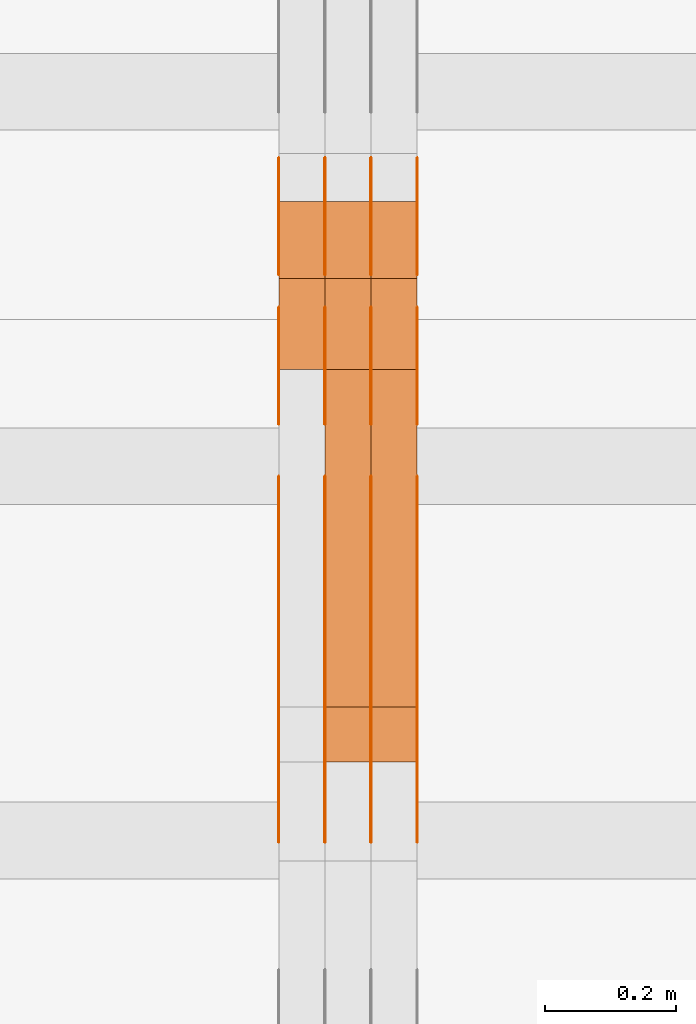
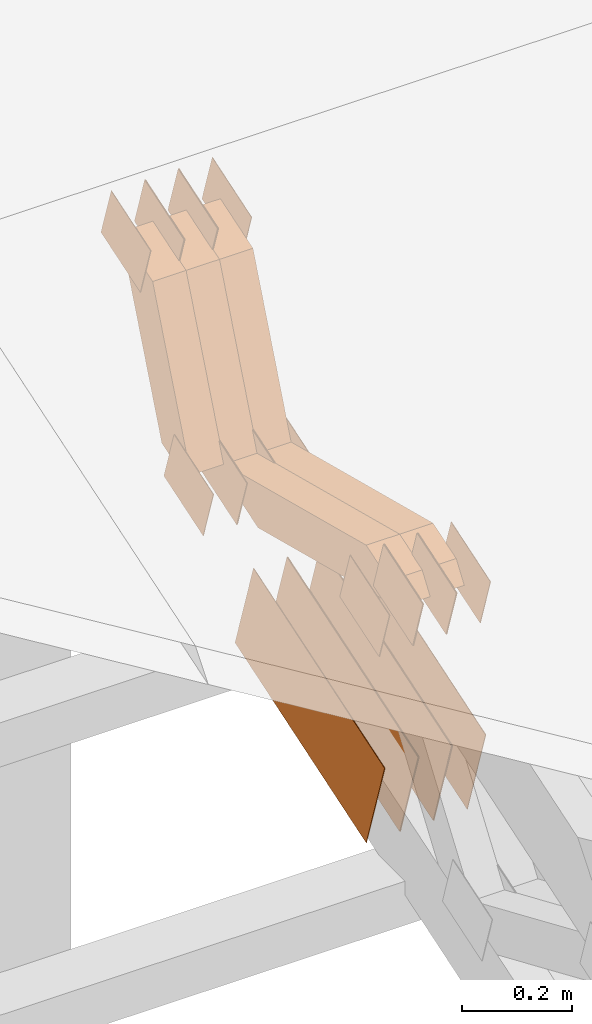
# One storey, part 314 of 385: 29 proxies.
"""IFC2X3 building model written with IfcOpenShell, lengths in millimetres."""

import ifcopenshell
import ifcopenshell.guid

model = None  # the IFC model being written
_history = None  # IfcOwnerHistory: only IFC2X3 demands one
_inside = {}  # id of a spatial element -> (the spatial element, [elements in it])
_under = {}  # id of a project, library or spatial element -> (it, [spatial elements below it])
_declared = {}  # id of a project -> (the project, [libraries it declares])
_typed = {}  # id of a type object -> (the type object, [elements of that type])
_made_of = {}  # id of a material, layer set ... -> (it, [elements and type objects made of it])


def new_model(schema):
    """Start an empty IFC model of exactly this schema.

    Asked for "IFC4X3", IfcOpenShell would pick the latest addendum, in which some entities
    have other attributes; the version numbers below select the first issue.
    IFC2X3 requires an IfcOwnerHistory on every rooted entity: one is made here for all.
    """
    global model, _history
    if schema == "IFC4X3":
        model = ifcopenshell.file(schema_version=(4, 3, 0, 0))
    else:
        model = ifcopenshell.file(schema=schema)
    _inside.clear()
    _under.clear()
    _declared.clear()
    _typed.clear()
    _made_of.clear()
    _history = None
    if model.schema == "IFC2X3":
        org = make("IfcOrganization", Name="unknown")
        user = make(
            "IfcPersonAndOrganization",
            ThePerson=make("IfcPerson", FamilyName="unknown"),
            TheOrganization=org,
        )
        app = make(
            "IfcApplication",
            ApplicationDeveloper=org,
            Version="unknown",
            ApplicationFullName="unknown",
            ApplicationIdentifier="unknown",
        )
        _history = make(
            "IfcOwnerHistory",
            OwningUser=user,
            OwningApplication=app,
            ChangeAction="ADDED",
            CreationDate=0,
        )
    return model


def make(cls, **values):
    """One entity of the class cls with the attributes given. An attribute that is None is left unset."""
    return model.create_entity(
        cls, **{name: value for name, value in values.items() if value is not None}
    )


def entity(cls, *values):
    """Any entity or typed value of the class cls, its attributes in the order of the schema. None: left unset."""
    e = model.create_entity(cls)
    for i, value in enumerate(values):
        if value is not None:
            e[i] = value
    return e


def rooted(cls, **values):
    """An entity with a GlobalId (a new one), such as an element, a storey or a relation."""
    return make(cls, GlobalId=ifcopenshell.guid.new(), OwnerHistory=_history, **values)


def si_unit(unit_type, name, prefix=None):
    """IfcSIUnit, for example si_unit("LENGTHUNIT", "METRE", prefix="MILLI")."""
    return make("IfcSIUnit", UnitType=unit_type, Prefix=prefix, Name=name)


def converted_unit(unit_type, name, factor, base, dimensions=None, offset=None):
    """IfcConversionBasedUnit, such as the inch: factor (a typed value) times the base unit."""
    return make(
        "IfcConversionBasedUnit"
        if offset is None
        else "IfcConversionBasedUnitWithOffset",
        ConversionOffset=offset,
        Dimensions=None
        if dimensions is None
        else entity("IfcDimensionalExponents", *dimensions),
        UnitType=unit_type,
        Name=name,
        ConversionFactor=make(
            "IfcMeasureWithUnit", ValueComponent=factor, UnitComponent=base
        ),
    )


def derived_unit(unit_type, elements):
    """IfcDerivedUnit: a product of units, each with its exponent."""
    return make(
        "IfcDerivedUnit",
        Elements=[
            make("IfcDerivedUnitElement", Unit=unit, Exponent=power)
            for unit, power in elements
        ],
        UnitType=unit_type,
    )


def assignment(units):
    """IfcUnitAssignment: the units of a project."""
    return None if units is None else make("IfcUnitAssignment", Units=units)


def point(xyz):
    """IfcCartesianPoint."""
    return None if xyz is None else make("IfcCartesianPoint", Coordinates=xyz)


def direction(xyz):
    """IfcDirection."""
    return None if xyz is None else make("IfcDirection", DirectionRatios=xyz)


def frame(location, z_axis=None, x_axis=None):
    """IfcAxis2Placement3D, a coordinate frame: its origin and axes. An axis left out is left unset."""
    return make(
        "IfcAxis2Placement3D",
        Location=point(location),
        Axis=direction(z_axis),
        RefDirection=direction(x_axis),
    )


def origin():
    """The frame at (0, 0, 0) with its axes left unset."""
    return frame((0.0, 0.0, 0.0))


def place(relative_to, where):
    """IfcLocalPlacement: puts the frame where relative to a parent placement (None: the world)."""
    return make(
        "IfcLocalPlacement", PlacementRelTo=relative_to, RelativePlacement=where
    )


def context(
    kind, dimensions, precision=None, world=None, true_north=None, identifier=None
):
    """IfcGeometricRepresentationContext, for example the 3D "Model" context."""
    return make(
        "IfcGeometricRepresentationContext",
        ContextIdentifier=identifier,
        ContextType=kind,
        CoordinateSpaceDimension=dimensions,
        Precision=precision,
        WorldCoordinateSystem=world,
        TrueNorth=true_north,
    )


def subcontext(parent, identifier, kind, view, scale=None):
    """IfcGeometricRepresentationSubContext, for example "Body" below "Model"."""
    return make(
        "IfcGeometricRepresentationSubContext",
        ContextIdentifier=identifier,
        ContextType=kind,
        ParentContext=parent,
        TargetScale=scale,
        TargetView=view,
    )


def project(units=None, contexts=None):
    """IfcProject with its units and contexts."""
    return rooted(
        "IfcProject",
        Name="project",
        RepresentationContexts=contexts,
        UnitsInContext=assignment(units),
    )


def spatial(cls, under=None, at=None, **own):
    """A site, building, storey or space (cls), placed at a placement, below another one or the project."""
    s = rooted(cls, ObjectPlacement=at, **own)
    if under is not None:
        _under.setdefault(under.id(), (under, []))[1].append(s)
    return s


def polyline(points):
    """IfcPolyline through the points."""
    return make("IfcPolyline", Points=[point(p) for p in points])


def outline(outer, holes=None, kind="AREA"):
    """IfcArbitraryClosedProfileDef: a profile drawn as a closed curve; with holes, ...WithVoids."""
    if holes is None:
        return make("IfcArbitraryClosedProfileDef", ProfileType=kind, OuterCurve=outer)
    return make(
        "IfcArbitraryProfileDefWithVoids",
        ProfileType=kind,
        OuterCurve=outer,
        InnerCurves=holes,
    )


def extrude(swept, where, along, depth):
    """IfcExtrudedAreaSolid: the profile swept, set in the frame where, extruded along a direction by depth."""
    return make(
        "IfcExtrudedAreaSolid",
        SweptArea=swept,
        Position=where,
        ExtrudedDirection=direction(along),
        Depth=depth,
    )


def shape(context_of_items, identifier, shape_type, items):
    """IfcShapeRepresentation: the items that make up one representation, for example the "Body"."""
    return make(
        "IfcShapeRepresentation",
        ContextOfItems=context_of_items,
        RepresentationIdentifier=identifier,
        RepresentationType=shape_type,
        Items=items,
    )


def source(mapping_origin, context_of_items, identifier, shape_type, items):
    """IfcRepresentationMap: a shape defined once, which mapped items show again and again."""
    return make(
        "IfcRepresentationMap",
        MappingOrigin=mapping_origin,
        MappedRepresentation=shape(context_of_items, identifier, shape_type, items),
    )


def transform(
    local_origin,
    x_axis=None,
    y_axis=None,
    z_axis=None,
    scale=None,
    scale2=None,
    scale3=None,
    uniform=True,
):
    """IfcCartesianTransformationOperator3D, or its non-uniform kind. x_axis, y_axis, z_axis: its Axis1, 2, 3."""
    if uniform:
        return make(
            "IfcCartesianTransformationOperator3D",
            Axis1=direction(x_axis),
            Axis2=direction(y_axis),
            LocalOrigin=point(local_origin),
            Scale=scale,
            Axis3=direction(z_axis),
        )
    return make(
        "IfcCartesianTransformationOperator3DnonUniform",
        Axis1=direction(x_axis),
        Axis2=direction(y_axis),
        LocalOrigin=point(local_origin),
        Scale=scale,
        Axis3=direction(z_axis),
        Scale2=scale2,
        Scale3=scale3,
    )


def mapped(mapping_source, mapping_target):
    """IfcMappedItem: shows the shape of a source again, moved by a transform."""
    return make(
        "IfcMappedItem", MappingSource=mapping_source, MappingTarget=mapping_target
    )


def material(Name=None, Category=None):
    """IfcMaterial."""
    return make("IfcMaterial", Name=Name, Category=Category)


def made_of(thing, what):
    """Note that an element or type object is made of a material, layer set ...; save() writes the relation."""
    if what is not None:
        _made_of.setdefault(what.id(), (what, []))[1].append(thing)
    return thing


def type_object(cls, material=None, **own):
    """A type object (cls), such as IfcWallType, which elements share."""
    return made_of(rooted(cls, **own), material)


def type_shapes(of_type, sources):
    """Give a type object the sources (RepresentationMaps) that its elements show as mapped items."""
    of_type.RepresentationMaps = sources


def element(
    cls,
    number,
    at=None,
    inside=None,
    cuts=None,
    type_object=None,
    material=None,
    context=None,
    identifier="Body",
    shape_type=None,
    held_by="IfcProductDefinitionShape",
    body=None,
    shapes=None,
    **own,
):
    """One element of the class cls, such as IfcWall. Its Tag is "e" and its number.

    at: its placement. inside: the storey or other place that contains it. cuts: it is an
    opening in that element (IfcRelVoidsElement). A single representation is given by context,
    identifier, shape_type and body (its items); several are given by shapes. held_by: the class
    of the entity that holds the representations. save() writes the other relations.
    """
    e = rooted(cls, Tag="e%d" % number, ObjectPlacement=at, **own)
    if body is not None:
        shapes = [shape(context, identifier, shape_type, body)]
    if shapes is not None:
        e.Representation = make(held_by, Representations=shapes)
    if inside is not None:
        _inside.setdefault(inside.id(), (inside, []))[1].append(e)
    if cuts is not None:
        rooted(
            "IfcRelVoidsElement", RelatingBuildingElement=cuts, RelatedOpeningElement=e
        )
    if type_object is not None:
        _typed.setdefault(type_object.id(), (type_object, []))[1].append(e)
    return made_of(e, material)


def aggregate(whole, parts):
    """IfcRelAggregates: a whole, such as a stair, and the parts it consists of."""
    return rooted("IfcRelAggregates", RelatingObject=whole, RelatedObjects=parts)


def save(model, path):
    """Write the relations noted so far, then the file.

    IfcRelAggregates (storeys below a building ...), IfcRelContainedInSpatialStructure (elements
    in a storey), IfcRelDefinesByType, IfcRelAssociatesMaterial and IfcRelDeclares: one each for
    every whole, place, type object, material and project.
    """
    for whole, parts in _under.values():
        aggregate(whole, parts)
    for where, things in _inside.values():
        rooted(
            "IfcRelContainedInSpatialStructure",
            RelatedElements=things,
            RelatingStructure=where,
        )
    for kind, things in _typed.values():
        rooted("IfcRelDefinesByType", RelatedObjects=things, RelatingType=kind)
    for what, things in _made_of.values():
        rooted("IfcRelAssociatesMaterial", RelatedObjects=things, RelatingMaterial=what)
    for by, libraries in _declared.values():
        rooted("IfcRelDeclares", RelatingContext=by, RelatedDefinitions=libraries)
    model.write(path)


model = new_model("IFC2X3")

# Units and contexts
model_context = context("Model", 3, precision=0.01, world=origin(), true_north=direction((6.12303176911189e-17, 1.0)))
body_context = subcontext(model_context, "Body", "Model", "MODEL_VIEW")
ifc_project = project(units=[si_unit("LENGTHUNIT", "METRE", prefix="MILLI"), si_unit("AREAUNIT", "SQUARE_METRE"), si_unit("VOLUMEUNIT", "CUBIC_METRE"), converted_unit("PLANEANGLEUNIT", "DEGREE", entity("IfcRatioMeasure", 0.0174532925199433), si_unit("PLANEANGLEUNIT", "RADIAN"), dimensions=[0, 0, 0, 0, 0, 0, 0]), si_unit("MASSUNIT", "GRAM", prefix="KILO"), derived_unit("MASSDENSITYUNIT", [(si_unit("MASSUNIT", "GRAM", prefix="KILO"), 1), (si_unit("LENGTHUNIT", "METRE"), -3)]), si_unit("TIMEUNIT", "SECOND"), si_unit("FREQUENCYUNIT", "HERTZ"), si_unit("THERMODYNAMICTEMPERATUREUNIT", "DEGREE_CELSIUS"), derived_unit("THERMALTRANSMITTANCEUNIT", [(si_unit("MASSUNIT", "GRAM", prefix="KILO"), 1), (si_unit("THERMODYNAMICTEMPERATUREUNIT", "KELVIN"), -1), (si_unit("TIMEUNIT", "SECOND"), -3)]), derived_unit("VOLUMETRICFLOWRATEUNIT", [(si_unit("LENGTHUNIT", "METRE"), 3), (si_unit("TIMEUNIT", "SECOND"), -1)]), si_unit("ELECTRICCURRENTUNIT", "AMPERE"), si_unit("ELECTRICVOLTAGEUNIT", "VOLT"), si_unit("POWERUNIT", "WATT"), si_unit("FORCEUNIT", "NEWTON", prefix="KILO"), si_unit("ILLUMINANCEUNIT", "LUX"), si_unit("LUMINOUSFLUXUNIT", "LUMEN"), si_unit("LUMINOUSINTENSITYUNIT", "CANDELA"), derived_unit("USERDEFINED", [(si_unit("MASSUNIT", "GRAM", prefix="KILO"), -1), (si_unit("LENGTHUNIT", "METRE"), -2), (si_unit("TIMEUNIT", "SECOND"), 3), (si_unit("LUMINOUSFLUXUNIT", "LUMEN"), 1)]), derived_unit("LINEARVELOCITYUNIT", [(si_unit("LENGTHUNIT", "METRE"), 1), (si_unit("TIMEUNIT", "SECOND"), -1)]), si_unit("PRESSUREUNIT", "PASCAL"), derived_unit("USERDEFINED", [(si_unit("LENGTHUNIT", "METRE"), -2), (si_unit("MASSUNIT", "GRAM", prefix="KILO"), 1), (si_unit("TIMEUNIT", "SECOND"), -2)])], contexts=[model_context])

# Site, building, storey
site_placement = place(None, origin())
site = spatial("IfcSite", under=ifc_project, at=site_placement, CompositionType="ELEMENT")
building_placement = place(site_placement, origin())
building = spatial("IfcBuilding", under=site, at=building_placement, CompositionType="ELEMENT")
storey_placement = place(building_placement, origin())
storey = spatial("IfcBuildingStorey", under=building, at=storey_placement, Name="Default", CompositionType="ELEMENT", Elevation=0.0)

# Proxies
ifc_material_1 = material(Name="IfcSurfaceStyle #591654")
building_element_proxy_type_1 = type_object("IfcBuildingElementProxyType", PredefinedType="NOTDEFINED", material=ifc_material_1)
shared_shape_1 = source(origin(), body_context, "Body", "SweptSolid", [
    extrude(outline(polyline([(-74.9998565677179, -60.000059685226), (74.9998794200128, -60.000059685226), (74.9998565677179, 60.000059685226), (-74.9998794200128, 60.000059685226), (-74.9998565677179, -60.000059685226)])), frame((75.0001976720505, 60.000059685226, 0.0), z_axis=(0.0, 0.0, 1.0), x_axis=(-1.0, 0.0, 0.0)), (0.0, 0.0, 1.0), 1.3),
])
type_shapes(building_element_proxy_type_1, [shared_shape_1])
proxy_1_placement = place(building_placement, frame((48386.3, 8537.53090236183, 1950.11166041942), z_axis=(-1.0, 0.0, 0.0), x_axis=(0.0, 0.951056516295124, 0.309016994375039)))
element("IfcBuildingElementProxy", 1, at=proxy_1_placement, inside=storey, type_object=building_element_proxy_type_1, material=ifc_material_1, context=body_context, shape_type="MappedRepresentation", body=[
    mapped(shared_shape_1, transform((0.0, 0.0, 0.0), scale=1.0)),
])
ifc_material_2 = material(Name="IfcSurfaceStyle #591597")
building_element_proxy_type_2 = type_object("IfcBuildingElementProxyType", PredefinedType="NOTDEFINED", material=ifc_material_2)
shared_shape_2 = source(origin(), body_context, "Body", "SweptSolid", [
    extrude(outline(polyline([(-74.9998565677179, -60.000059685226), (74.9998794200128, -60.000059685226), (74.9998565677179, 60.000059685226), (-74.9998794200128, 60.000059685226), (-74.9998565677179, -60.000059685226)])), frame((75.0001976720505, 60.000059685226, 0.0), z_axis=(0.0, 0.0, 1.0), x_axis=(-1.0, 0.0, 0.0)), (0.0, 0.0, 1.0), 1.3),
])
type_shapes(building_element_proxy_type_2, [shared_shape_2])
proxy_2_placement = place(building_placement, frame((48315.0, 8537.53090236183, 1950.11166041942), z_axis=(-1.0, 0.0, 0.0), x_axis=(0.0, 0.951056516295124, 0.309016994375039)))
element("IfcBuildingElementProxy", 2, at=proxy_2_placement, inside=storey, type_object=building_element_proxy_type_2, material=ifc_material_2, context=body_context, shape_type="MappedRepresentation", body=[
    mapped(shared_shape_2, transform((0.0, 0.0, 0.0), scale=1.0)),
])
ifc_material_3 = material(Name="IfcSurfaceStyle #591540")
building_element_proxy_type_3 = type_object("IfcBuildingElementProxyType", PredefinedType="NOTDEFINED", material=ifc_material_3)
shared_shape_3 = source(origin(), body_context, "Body", "SweptSolid", [
    extrude(outline(polyline([(-74.9998565677179, -60.000059685226), (74.9998794200128, -60.000059685226), (74.9998565677179, 60.000059685226), (-74.9998794200128, 60.000059685226), (-74.9998565677179, -60.000059685226)])), frame((75.0001976720505, 60.000059685226, 0.0), z_axis=(0.0, 0.0, 1.0), x_axis=(-1.0, 0.0, 0.0)), (0.0, 0.0, 1.0), 1.3),
])
type_shapes(building_element_proxy_type_3, [shared_shape_3])
proxy_3_placement = place(building_placement, frame((48316.3, 8537.53090236183, 1950.11166041942), z_axis=(-1.0, 0.0, 0.0), x_axis=(0.0, 0.951056516295124, 0.309016994375039)))
element("IfcBuildingElementProxy", 3, at=proxy_3_placement, inside=storey, type_object=building_element_proxy_type_3, material=ifc_material_3, context=body_context, shape_type="MappedRepresentation", body=[
    mapped(shared_shape_3, transform((0.0, 0.0, 0.0), scale=1.0)),
])
ifc_material_4 = material(Name="IfcSurfaceStyle #591483")
building_element_proxy_type_4 = type_object("IfcBuildingElementProxyType", PredefinedType="NOTDEFINED", material=ifc_material_4)
shared_shape_4 = source(origin(), body_context, "Body", "SweptSolid", [
    extrude(outline(polyline([(-74.9998565677179, -60.000059685226), (74.9998794200128, -60.000059685226), (74.9998565677179, 60.000059685226), (-74.9998794200128, 60.000059685226), (-74.9998565677179, -60.000059685226)])), frame((75.0001976720505, 60.000059685226, 0.0), z_axis=(0.0, 0.0, 1.0), x_axis=(-1.0, 0.0, 0.0)), (0.0, 0.0, 1.0), 1.29999999999999),
])
type_shapes(building_element_proxy_type_4, [shared_shape_4])
proxy_4_placement = place(building_placement, frame((48245.0, 8537.53090236183, 1950.11166041942), z_axis=(-1.0, 0.0, 0.0), x_axis=(0.0, 0.951056516295124, 0.309016994375039)))
element("IfcBuildingElementProxy", 4, at=proxy_4_placement, inside=storey, type_object=building_element_proxy_type_4, material=ifc_material_4, context=body_context, shape_type="MappedRepresentation", body=[
    mapped(shared_shape_4, transform((0.0, 0.0, 0.0), scale=1.0)),
])
ifc_material_5 = material(Name="IfcSurfaceStyle #591426")
building_element_proxy_type_5 = type_object("IfcBuildingElementProxyType", PredefinedType="NOTDEFINED", material=ifc_material_5)
shared_shape_5 = source(origin(), body_context, "Body", "SweptSolid", [
    extrude(outline(polyline([(-74.9998565677179, -60.000059685226), (74.9998794200128, -60.000059685226), (74.9998565677179, 60.000059685226), (-74.9998794200128, 60.000059685226), (-74.9998565677179, -60.000059685226)])), frame((75.0001976720505, 60.000059685226, 0.0), z_axis=(0.0, 0.0, 1.0), x_axis=(-1.0, 0.0, 0.0)), (0.0, 0.0, 1.0), 1.29999999999999),
])
type_shapes(building_element_proxy_type_5, [shared_shape_5])
proxy_5_placement = place(building_placement, frame((48246.3, 8537.53090236183, 1950.11166041942), z_axis=(-1.0, 0.0, 0.0), x_axis=(0.0, 0.951056516295124, 0.309016994375039)))
element("IfcBuildingElementProxy", 5, at=proxy_5_placement, inside=storey, type_object=building_element_proxy_type_5, material=ifc_material_5, context=body_context, shape_type="MappedRepresentation", body=[
    mapped(shared_shape_5, transform((0.0, 0.0, 0.0), scale=1.0)),
])
ifc_material_6 = material(Name="IfcSurfaceStyle #591369")
building_element_proxy_type_6 = type_object("IfcBuildingElementProxyType", PredefinedType="NOTDEFINED", material=ifc_material_6)
shared_shape_6 = source(origin(), body_context, "Body", "SweptSolid", [
    extrude(outline(polyline([(-74.9998565677179, -60.000059685226), (74.9998794200128, -60.000059685226), (74.9998565677179, 60.000059685226), (-74.9998794200128, 60.000059685226), (-74.9998565677179, -60.000059685226)])), frame((75.0001976720505, 60.000059685226, 0.0), z_axis=(0.0, 0.0, 1.0), x_axis=(-1.0, 0.0, 0.0)), (0.0, 0.0, 1.0), 1.29999999999999),
])
type_shapes(building_element_proxy_type_6, [shared_shape_6])
proxy_6_placement = place(building_placement, frame((48175.0, 8537.53090236183, 1950.11166041942), z_axis=(-1.0, 0.0, 0.0), x_axis=(0.0, 0.951056516295124, 0.309016994375039)))
element("IfcBuildingElementProxy", 6, at=proxy_6_placement, inside=storey, type_object=building_element_proxy_type_6, material=ifc_material_6, context=body_context, shape_type="MappedRepresentation", body=[
    mapped(shared_shape_6, transform((0.0, 0.0, 0.0), scale=1.0)),
])
ifc_material_7 = material(Name="IfcSurfaceStyle #591312")
building_element_proxy_type_7 = type_object("IfcBuildingElementProxyType", PredefinedType="NOTDEFINED", material=ifc_material_7)
shared_shape_7 = source(origin(), body_context, "Body", "SweptSolid", [
    extrude(outline(polyline([(-74.9998754286225, -60.0000016373515), (74.9998605591045, -60.0000016373515), (74.9998754286225, 60.0000016373515), (-74.9998605591045, 60.0000016373515), (-74.9998754286225, -60.0000016373515)])), frame((74.9998754286225, 60.0000016373515, 0.0), z_axis=(0.0, 0.0, 1.0), x_axis=(-1.0, 0.0, 0.0)), (0.0, 0.0, 1.0), 1.3),
])
type_shapes(building_element_proxy_type_7, [shared_shape_7])
proxy_7_placement = place(building_placement, frame((48386.3, 8765.47458614632, 2350.86432930304), z_axis=(-1.0, 0.0, 0.0), x_axis=(0.0, 0.951056516295154, 0.309016994374948)))
element("IfcBuildingElementProxy", 7, at=proxy_7_placement, inside=storey, type_object=building_element_proxy_type_7, material=ifc_material_7, context=body_context, shape_type="MappedRepresentation", body=[
    mapped(shared_shape_7, transform((0.0, 0.0, 0.0), scale=1.0)),
])
ifc_material_8 = material(Name="IfcSurfaceStyle #591255")
building_element_proxy_type_8 = type_object("IfcBuildingElementProxyType", PredefinedType="NOTDEFINED", material=ifc_material_8)
shared_shape_8 = source(origin(), body_context, "Body", "SweptSolid", [
    extrude(outline(polyline([(-74.9998754286225, -60.0000016373515), (74.9998605591045, -60.0000016373515), (74.9998754286225, 60.0000016373515), (-74.9998605591045, 60.0000016373515), (-74.9998754286225, -60.0000016373515)])), frame((74.9998754286225, 60.0000016373515, 0.0), z_axis=(0.0, 0.0, 1.0), x_axis=(-1.0, 0.0, 0.0)), (0.0, 0.0, 1.0), 1.3),
])
type_shapes(building_element_proxy_type_8, [shared_shape_8])
proxy_8_placement = place(building_placement, frame((48315.0, 8765.47458614632, 2350.86432930304), z_axis=(-1.0, 0.0, 0.0), x_axis=(0.0, 0.951056516295154, 0.309016994374948)))
element("IfcBuildingElementProxy", 8, at=proxy_8_placement, inside=storey, type_object=building_element_proxy_type_8, material=ifc_material_8, context=body_context, shape_type="MappedRepresentation", body=[
    mapped(shared_shape_8, transform((0.0, 0.0, 0.0), scale=1.0)),
])
ifc_material_9 = material(Name="IfcSurfaceStyle #591198")
building_element_proxy_type_9 = type_object("IfcBuildingElementProxyType", PredefinedType="NOTDEFINED", material=ifc_material_9)
shared_shape_9 = source(origin(), body_context, "Body", "SweptSolid", [
    extrude(outline(polyline([(-74.9998754286225, -60.0000016373515), (74.9998605591045, -60.0000016373515), (74.9998754286225, 60.0000016373515), (-74.9998605591045, 60.0000016373515), (-74.9998754286225, -60.0000016373515)])), frame((74.9998754286225, 60.0000016373515, 0.0), z_axis=(0.0, 0.0, 1.0), x_axis=(-1.0, 0.0, 0.0)), (0.0, 0.0, 1.0), 1.3),
])
type_shapes(building_element_proxy_type_9, [shared_shape_9])
proxy_9_placement = place(building_placement, frame((48316.3, 8765.47458614632, 2350.86432930304), z_axis=(-1.0, 0.0, 0.0), x_axis=(0.0, 0.951056516295154, 0.309016994374948)))
element("IfcBuildingElementProxy", 9, at=proxy_9_placement, inside=storey, type_object=building_element_proxy_type_9, material=ifc_material_9, context=body_context, shape_type="MappedRepresentation", body=[
    mapped(shared_shape_9, transform((0.0, 0.0, 0.0), scale=1.0)),
])
ifc_material_10 = material(Name="IfcSurfaceStyle #591141")
building_element_proxy_type_10 = type_object("IfcBuildingElementProxyType", PredefinedType="NOTDEFINED", material=ifc_material_10)
shared_shape_10 = source(origin(), body_context, "Body", "SweptSolid", [
    extrude(outline(polyline([(-74.9998754286225, -60.0000016373515), (74.9998605591045, -60.0000016373515), (74.9998754286225, 60.0000016373515), (-74.9998605591045, 60.0000016373515), (-74.9998754286225, -60.0000016373515)])), frame((74.9998754286225, 60.0000016373515, 0.0), z_axis=(0.0, 0.0, 1.0), x_axis=(-1.0, 0.0, 0.0)), (0.0, 0.0, 1.0), 1.29999999999999),
])
type_shapes(building_element_proxy_type_10, [shared_shape_10])
proxy_10_placement = place(building_placement, frame((48245.0, 8765.47458614632, 2350.86432930304), z_axis=(-1.0, 0.0, 0.0), x_axis=(0.0, 0.951056516295154, 0.309016994374948)))
element("IfcBuildingElementProxy", 10, at=proxy_10_placement, inside=storey, type_object=building_element_proxy_type_10, material=ifc_material_10, context=body_context, shape_type="MappedRepresentation", body=[
    mapped(shared_shape_10, transform((0.0, 0.0, 0.0), scale=1.0)),
])
ifc_material_11 = material(Name="IfcSurfaceStyle #591084")
building_element_proxy_type_11 = type_object("IfcBuildingElementProxyType", PredefinedType="NOTDEFINED", material=ifc_material_11)
shared_shape_11 = source(origin(), body_context, "Body", "SweptSolid", [
    extrude(outline(polyline([(-74.9998754286225, -60.0000016373515), (74.9998605591045, -60.0000016373515), (74.9998754286225, 60.0000016373515), (-74.9998605591045, 60.0000016373515), (-74.9998754286225, -60.0000016373515)])), frame((74.9998754286225, 60.0000016373515, 0.0), z_axis=(0.0, 0.0, 1.0), x_axis=(-1.0, 0.0, 0.0)), (0.0, 0.0, 1.0), 1.29999999999999),
])
type_shapes(building_element_proxy_type_11, [shared_shape_11])
proxy_11_placement = place(building_placement, frame((48246.3, 8765.47458614632, 2350.86432930304), z_axis=(-1.0, 0.0, 0.0), x_axis=(0.0, 0.951056516295154, 0.309016994374948)))
element("IfcBuildingElementProxy", 11, at=proxy_11_placement, inside=storey, type_object=building_element_proxy_type_11, material=ifc_material_11, context=body_context, shape_type="MappedRepresentation", body=[
    mapped(shared_shape_11, transform((0.0, 0.0, 0.0), scale=1.0)),
])
ifc_material_12 = material(Name="IfcSurfaceStyle #591027")
building_element_proxy_type_12 = type_object("IfcBuildingElementProxyType", PredefinedType="NOTDEFINED", material=ifc_material_12)
shared_shape_12 = source(origin(), body_context, "Body", "SweptSolid", [
    extrude(outline(polyline([(-74.9998754286225, -60.0000016373515), (74.9998605591045, -60.0000016373515), (74.9998754286225, 60.0000016373515), (-74.9998605591045, 60.0000016373515), (-74.9998754286225, -60.0000016373515)])), frame((74.9998754286225, 60.0000016373515, 0.0), z_axis=(0.0, 0.0, 1.0), x_axis=(-1.0, 0.0, 0.0)), (0.0, 0.0, 1.0), 1.29999999999999),
])
type_shapes(building_element_proxy_type_12, [shared_shape_12])
proxy_12_placement = place(building_placement, frame((48175.0, 8765.47458614632, 2350.86432930304), z_axis=(-1.0, 0.0, 0.0), x_axis=(0.0, 0.951056516295154, 0.309016994374948)))
element("IfcBuildingElementProxy", 12, at=proxy_12_placement, inside=storey, type_object=building_element_proxy_type_12, material=ifc_material_12, context=body_context, shape_type="MappedRepresentation", body=[
    mapped(shared_shape_12, transform((0.0, 0.0, 0.0), scale=1.0)),
])
ifc_material_13 = material(Name="IfcSurfaceStyle #590628")
building_element_proxy_type_13 = type_object("IfcBuildingElementProxyType", PredefinedType="NOTDEFINED", material=ifc_material_13)
shared_shape_13 = source(origin(), body_context, "Body", "SweptSolid", [
    extrude(outline(polyline([(-249.999749056184, -108.000229288163), (249.999396050782, -108.000229288163), (249.999749056184, 108.000229288163), (-249.999396050782, 108.000229288163), (-249.999749056184, -108.000229288163)])), frame((249.999841104007, 108.000229288163, 0.0), z_axis=(0.0, 0.0, 1.0), x_axis=(-1.0, 0.0, 0.0)), (0.0, 0.0, 1.0), 1.29999999999998),
])
type_shapes(building_element_proxy_type_13, [shared_shape_13])
proxy_13_placement = place(building_placement, frame((48386.3, 7917.13457673635, 1720.66532252899), z_axis=(-1.0, 0.0, 0.0), x_axis=(0.0, 0.951056516295124, 0.309016994375039)))
element("IfcBuildingElementProxy", 13, at=proxy_13_placement, inside=storey, type_object=building_element_proxy_type_13, material=ifc_material_13, context=body_context, shape_type="MappedRepresentation", body=[
    mapped(shared_shape_13, transform((0.0, 0.0, 0.0), scale=1.0)),
])
ifc_material_14 = material(Name="IfcSurfaceStyle #590571")
building_element_proxy_type_14 = type_object("IfcBuildingElementProxyType", PredefinedType="NOTDEFINED", material=ifc_material_14)
shared_shape_14 = source(origin(), body_context, "Body", "SweptSolid", [
    extrude(outline(polyline([(-249.999749056184, -108.000229288163), (249.999396050782, -108.000229288163), (249.999749056184, 108.000229288163), (-249.999396050782, 108.000229288163), (-249.999749056184, -108.000229288163)])), frame((249.999841104007, 108.000229288163, 0.0), z_axis=(0.0, 0.0, 1.0), x_axis=(-1.0, 0.0, 0.0)), (0.0, 0.0, 1.0), 1.29999999999998),
])
type_shapes(building_element_proxy_type_14, [shared_shape_14])
proxy_14_placement = place(building_placement, frame((48315.0, 7917.13457673635, 1720.66532252899), z_axis=(-1.0, 0.0, 0.0), x_axis=(0.0, 0.951056516295124, 0.309016994375039)))
element("IfcBuildingElementProxy", 14, at=proxy_14_placement, inside=storey, type_object=building_element_proxy_type_14, material=ifc_material_14, context=body_context, shape_type="MappedRepresentation", body=[
    mapped(shared_shape_14, transform((0.0, 0.0, 0.0), scale=1.0)),
])
ifc_material_15 = material(Name="IfcSurfaceStyle #590514")
building_element_proxy_type_15 = type_object("IfcBuildingElementProxyType", PredefinedType="NOTDEFINED", material=ifc_material_15)
shared_shape_15 = source(origin(), body_context, "Body", "SweptSolid", [
    extrude(outline(polyline([(-249.999749056184, -108.000229288163), (249.999396050782, -108.000229288163), (249.999749056184, 108.000229288163), (-249.999396050782, 108.000229288163), (-249.999749056184, -108.000229288163)])), frame((249.999841104007, 108.000229288163, 0.0), z_axis=(0.0, 0.0, 1.0), x_axis=(-1.0, 0.0, 0.0)), (0.0, 0.0, 1.0), 1.29999999999998),
])
type_shapes(building_element_proxy_type_15, [shared_shape_15])
proxy_15_placement = place(building_placement, frame((48316.3, 7917.13457673635, 1720.66532252899), z_axis=(-1.0, 0.0, 0.0), x_axis=(0.0, 0.951056516295124, 0.309016994375039)))
element("IfcBuildingElementProxy", 15, at=proxy_15_placement, inside=storey, type_object=building_element_proxy_type_15, material=ifc_material_15, context=body_context, shape_type="MappedRepresentation", body=[
    mapped(shared_shape_15, transform((0.0, 0.0, 0.0), scale=1.0)),
])
ifc_material_16 = material(Name="IfcSurfaceStyle #590457")
building_element_proxy_type_16 = type_object("IfcBuildingElementProxyType", PredefinedType="NOTDEFINED", material=ifc_material_16)
shared_shape_16 = source(origin(), body_context, "Body", "SweptSolid", [
    extrude(outline(polyline([(-249.999749056184, -108.000229288163), (249.999396050782, -108.000229288163), (249.999749056184, 108.000229288163), (-249.999396050782, 108.000229288163), (-249.999749056184, -108.000229288163)])), frame((249.999841104007, 108.000229288163, 0.0), z_axis=(0.0, 0.0, 1.0), x_axis=(-1.0, 0.0, 0.0)), (0.0, 0.0, 1.0), 1.29999999999997),
])
type_shapes(building_element_proxy_type_16, [shared_shape_16])
proxy_16_placement = place(building_placement, frame((48245.0, 7917.13457673635, 1720.66532252899), z_axis=(-1.0, 0.0, 0.0), x_axis=(0.0, 0.951056516295124, 0.309016994375039)))
element("IfcBuildingElementProxy", 16, at=proxy_16_placement, inside=storey, type_object=building_element_proxy_type_16, material=ifc_material_16, context=body_context, shape_type="MappedRepresentation", body=[
    mapped(shared_shape_16, transform((0.0, 0.0, 0.0), scale=1.0)),
])
ifc_material_17 = material(Name="IfcSurfaceStyle #590400")
building_element_proxy_type_17 = type_object("IfcBuildingElementProxyType", PredefinedType="NOTDEFINED", material=ifc_material_17)
shared_shape_17 = source(origin(), body_context, "Body", "SweptSolid", [
    extrude(outline(polyline([(-249.999749056184, -108.000229288163), (249.999396050782, -108.000229288163), (249.999749056184, 108.000229288163), (-249.999396050782, 108.000229288163), (-249.999749056184, -108.000229288163)])), frame((249.999841104007, 108.000229288163, 0.0), z_axis=(0.0, 0.0, 1.0), x_axis=(-1.0, 0.0, 0.0)), (0.0, 0.0, 1.0), 1.29999999999997),
])
type_shapes(building_element_proxy_type_17, [shared_shape_17])
proxy_17_placement = place(building_placement, frame((48246.3, 7917.13457673635, 1720.66532252899), z_axis=(-1.0, 0.0, 0.0), x_axis=(0.0, 0.951056516295124, 0.309016994375039)))
element("IfcBuildingElementProxy", 17, at=proxy_17_placement, inside=storey, type_object=building_element_proxy_type_17, material=ifc_material_17, context=body_context, shape_type="MappedRepresentation", body=[
    mapped(shared_shape_17, transform((0.0, 0.0, 0.0), scale=1.0)),
])
ifc_material_18 = material(Name="IfcSurfaceStyle #590343")
building_element_proxy_type_18 = type_object("IfcBuildingElementProxyType", PredefinedType="NOTDEFINED", material=ifc_material_18)
shared_shape_18 = source(origin(), body_context, "Body", "SweptSolid", [
    extrude(outline(polyline([(-249.999749056184, -108.000229288163), (249.999396050782, -108.000229288163), (249.999749056184, 108.000229288163), (-249.999396050782, 108.000229288163), (-249.999749056184, -108.000229288163)])), frame((249.999841104007, 108.000229288163, 0.0), z_axis=(0.0, 0.0, 1.0), x_axis=(-1.0, 0.0, 0.0)), (0.0, 0.0, 1.0), 1.29999999999997),
])
type_shapes(building_element_proxy_type_18, [shared_shape_18])
proxy_18_placement = place(building_placement, frame((48175.0, 7917.13457673635, 1720.66532252899), z_axis=(-1.0, 0.0, 0.0), x_axis=(0.0, 0.951056516295124, 0.309016994375039)))
element("IfcBuildingElementProxy", 18, at=proxy_18_placement, inside=storey, type_object=building_element_proxy_type_18, material=ifc_material_18, context=body_context, shape_type="MappedRepresentation", body=[
    mapped(shared_shape_18, transform((0.0, 0.0, 0.0), scale=1.0)),
])
ifc_material_19 = material(Name="IfcSurfaceStyle #576948")
building_element_proxy_type_19 = type_object("IfcBuildingElementProxyType", PredefinedType="NOTDEFINED", material=ifc_material_19)
shared_shape_19 = source(origin(), body_context, "Body", "SweptSolid", [
    extrude(outline(polyline([(-74.9998754286253, -60.0000016373506), (74.9998605591091, -60.0000016373506), (74.9998754286234, 60.0000016373506), (-74.9998605591072, 60.0000016373506), (-74.9998754286253, -60.0000016373506)])), frame((75.0007355357002, 60.0002637031812, 0.0), z_axis=(0.0, 0.0, 1.0), x_axis=(-1.0, 0.0, 0.0)), (0.0, 0.0, 1.0), 1.3),
])
type_shapes(building_element_proxy_type_19, [shared_shape_19])
proxy_19_placement = place(building_placement, frame((48386.3, 7899.79204652809, 2069.58672486412), z_axis=(-1.0, 0.0, 0.0), x_axis=(0.0, 0.951056516295154, 0.309016994374948)))
element("IfcBuildingElementProxy", 19, at=proxy_19_placement, inside=storey, type_object=building_element_proxy_type_19, material=ifc_material_19, context=body_context, shape_type="MappedRepresentation", body=[
    mapped(shared_shape_19, transform((0.0, 0.0, 0.0), scale=1.0)),
])
ifc_material_20 = material(Name="IfcSurfaceStyle #576891")
building_element_proxy_type_20 = type_object("IfcBuildingElementProxyType", PredefinedType="NOTDEFINED", material=ifc_material_20)
shared_shape_20 = source(origin(), body_context, "Body", "SweptSolid", [
    extrude(outline(polyline([(-74.9998754286253, -60.0000016373506), (74.9998605591091, -60.0000016373506), (74.9998754286234, 60.0000016373506), (-74.9998605591072, 60.0000016373506), (-74.9998754286253, -60.0000016373506)])), frame((75.0007355357002, 60.0002637031812, 0.0), z_axis=(0.0, 0.0, 1.0), x_axis=(-1.0, 0.0, 0.0)), (0.0, 0.0, 1.0), 1.3),
])
type_shapes(building_element_proxy_type_20, [shared_shape_20])
proxy_20_placement = place(building_placement, frame((48315.0, 7899.79204652809, 2069.58672486412), z_axis=(-1.0, 0.0, 0.0), x_axis=(0.0, 0.951056516295154, 0.309016994374948)))
element("IfcBuildingElementProxy", 20, at=proxy_20_placement, inside=storey, type_object=building_element_proxy_type_20, material=ifc_material_20, context=body_context, shape_type="MappedRepresentation", body=[
    mapped(shared_shape_20, transform((0.0, 0.0, 0.0), scale=1.0)),
])
ifc_material_21 = material(Name="IfcSurfaceStyle #576834")
building_element_proxy_type_21 = type_object("IfcBuildingElementProxyType", PredefinedType="NOTDEFINED", material=ifc_material_21)
shared_shape_21 = source(origin(), body_context, "Body", "SweptSolid", [
    extrude(outline(polyline([(-74.9998754286253, -60.0000016373506), (74.9998605591091, -60.0000016373506), (74.9998754286234, 60.0000016373506), (-74.9998605591072, 60.0000016373506), (-74.9998754286253, -60.0000016373506)])), frame((75.0007355357002, 60.0002637031812, 0.0), z_axis=(0.0, 0.0, 1.0), x_axis=(-1.0, 0.0, 0.0)), (0.0, 0.0, 1.0), 1.3),
])
type_shapes(building_element_proxy_type_21, [shared_shape_21])
proxy_21_placement = place(building_placement, frame((48316.3, 7899.79204652809, 2069.58672486412), z_axis=(-1.0, 0.0, 0.0), x_axis=(0.0, 0.951056516295154, 0.309016994374948)))
element("IfcBuildingElementProxy", 21, at=proxy_21_placement, inside=storey, type_object=building_element_proxy_type_21, material=ifc_material_21, context=body_context, shape_type="MappedRepresentation", body=[
    mapped(shared_shape_21, transform((0.0, 0.0, 0.0), scale=1.0)),
])
ifc_material_22 = material(Name="IfcSurfaceStyle #576777")
building_element_proxy_type_22 = type_object("IfcBuildingElementProxyType", PredefinedType="NOTDEFINED", material=ifc_material_22)
shared_shape_22 = source(origin(), body_context, "Body", "SweptSolid", [
    extrude(outline(polyline([(-74.9998754286253, -60.0000016373506), (74.9998605591091, -60.0000016373506), (74.9998754286234, 60.0000016373506), (-74.9998605591072, 60.0000016373506), (-74.9998754286253, -60.0000016373506)])), frame((75.0007355357002, 60.0002637031812, 0.0), z_axis=(0.0, 0.0, 1.0), x_axis=(-1.0, 0.0, 0.0)), (0.0, 0.0, 1.0), 1.29999999999999),
])
type_shapes(building_element_proxy_type_22, [shared_shape_22])
proxy_22_placement = place(building_placement, frame((48245.0, 7899.79204652809, 2069.58672486412), z_axis=(-1.0, 0.0, 0.0), x_axis=(0.0, 0.951056516295154, 0.309016994374948)))
element("IfcBuildingElementProxy", 22, at=proxy_22_placement, inside=storey, type_object=building_element_proxy_type_22, material=ifc_material_22, context=body_context, shape_type="MappedRepresentation", body=[
    mapped(shared_shape_22, transform((0.0, 0.0, 0.0), scale=1.0)),
])
ifc_material_23 = material(Name="IfcSurfaceStyle #576720")
building_element_proxy_type_23 = type_object("IfcBuildingElementProxyType", PredefinedType="NOTDEFINED", material=ifc_material_23)
shared_shape_23 = source(origin(), body_context, "Body", "SweptSolid", [
    extrude(outline(polyline([(-74.9998754286253, -60.0000016373506), (74.9998605591091, -60.0000016373506), (74.9998754286234, 60.0000016373506), (-74.9998605591072, 60.0000016373506), (-74.9998754286253, -60.0000016373506)])), frame((75.0007355357002, 60.0002637031812, 0.0), z_axis=(0.0, 0.0, 1.0), x_axis=(-1.0, 0.0, 0.0)), (0.0, 0.0, 1.0), 1.29999999999999),
])
type_shapes(building_element_proxy_type_23, [shared_shape_23])
proxy_23_placement = place(building_placement, frame((48246.3, 7899.79204652809, 2069.58672486412), z_axis=(-1.0, 0.0, 0.0), x_axis=(0.0, 0.951056516295154, 0.309016994374948)))
element("IfcBuildingElementProxy", 23, at=proxy_23_placement, inside=storey, type_object=building_element_proxy_type_23, material=ifc_material_23, context=body_context, shape_type="MappedRepresentation", body=[
    mapped(shared_shape_23, transform((0.0, 0.0, 0.0), scale=1.0)),
])
ifc_material_24 = material(Name="IfcSurfaceStyle #576663")
building_element_proxy_type_24 = type_object("IfcBuildingElementProxyType", PredefinedType="NOTDEFINED", material=ifc_material_24)
shared_shape_24 = source(origin(), body_context, "Body", "SweptSolid", [
    extrude(outline(polyline([(-74.9998754286253, -60.0000016373506), (74.9998605591091, -60.0000016373506), (74.9998754286234, 60.0000016373506), (-74.9998605591072, 60.0000016373506), (-74.9998754286253, -60.0000016373506)])), frame((75.0007355357002, 60.0002637031812, 0.0), z_axis=(0.0, 0.0, 1.0), x_axis=(-1.0, 0.0, 0.0)), (0.0, 0.0, 1.0), 1.29999999999999),
])
type_shapes(building_element_proxy_type_24, [shared_shape_24])
proxy_24_placement = place(building_placement, frame((48175.0, 7899.79204652809, 2069.58672486412), z_axis=(-1.0, 0.0, 0.0), x_axis=(0.0, 0.951056516295154, 0.309016994374948)))
element("IfcBuildingElementProxy", 24, at=proxy_24_placement, inside=storey, type_object=building_element_proxy_type_24, material=ifc_material_24, context=body_context, shape_type="MappedRepresentation", body=[
    mapped(shared_shape_24, transform((0.0, 0.0, 0.0), scale=1.0)),
])
ifc_material_25 = material(Name="IfcSurfaceStyle #564564")
building_element_proxy_type_25 = type_object("IfcBuildingElementProxyType", Name="T1-W45 564562", PredefinedType="NOTDEFINED", material=ifc_material_25)
shared_shape_25 = source(origin(), body_context, "Body", "SweptSolid", [
    extrude(outline(polyline([(-275.953018340717, -47.500197738425), (128.971267956636, -47.5001977384251), (168.669977842085, -0.000132525443043008), (174.867371111815, 47.5002640011466), (-196.55559856982, 47.5002640011466), (-275.953018340717, -47.500197738425)])), frame((174.867371111815, 47.5002640011466, 0.0), z_axis=(0.0, 0.0, 1.0), x_axis=(-1.0, 0.0, 0.0)), (0.0, 0.0, 1.0), 70.0),
])
type_shapes(building_element_proxy_type_25, [shared_shape_25])
proxy_25_placement = place(building_placement, frame((48385.0, 8621.49414062501, 1941.33422851563), z_axis=(-1.0, 0.0, 0.0), x_axis=(0.0, 0.372787901688292, 0.927916580493549)))
element("IfcBuildingElementProxy", 25, at=proxy_25_placement, inside=storey, type_object=building_element_proxy_type_25, material=ifc_material_25, Name="T1-W45", context=body_context, shape_type="MappedRepresentation", body=[
    mapped(shared_shape_25, transform((0.0, 0.0, 0.0), scale=1.0)),
])
ifc_material_26 = material(Name="IfcSurfaceStyle #564498")
building_element_proxy_type_26 = type_object("IfcBuildingElementProxyType", Name="T1-W45 564496", PredefinedType="NOTDEFINED", material=ifc_material_26)
shared_shape_26 = source(origin(), body_context, "Body", "SweptSolid", [
    extrude(outline(polyline([(-275.953018340717, -47.500197738425), (128.971267956636, -47.5001977384251), (168.669977842085, -0.000132525443043008), (174.867371111815, 47.5002640011466), (-196.55559856982, 47.5002640011466), (-275.953018340717, -47.500197738425)])), frame((174.867371111815, 47.5002640011466, 0.0), z_axis=(0.0, 0.0, 1.0), x_axis=(-1.0, 0.0, 0.0)), (0.0, 0.0, 1.0), 70.0),
])
type_shapes(building_element_proxy_type_26, [shared_shape_26])
proxy_26_placement = place(building_placement, frame((48315.0, 8621.49414062501, 1941.33422851563), z_axis=(-1.0, 0.0, 0.0), x_axis=(0.0, 0.372787901688292, 0.927916580493549)))
element("IfcBuildingElementProxy", 26, at=proxy_26_placement, inside=storey, type_object=building_element_proxy_type_26, material=ifc_material_26, Name="T1-W45", context=body_context, shape_type="MappedRepresentation", body=[
    mapped(shared_shape_26, transform((0.0, 0.0, 0.0), scale=1.0)),
])
ifc_material_27 = material(Name="IfcSurfaceStyle #564432")
building_element_proxy_type_27 = type_object("IfcBuildingElementProxyType", Name="T1-W45 564430", PredefinedType="NOTDEFINED", material=ifc_material_27)
shared_shape_27 = source(origin(), body_context, "Body", "SweptSolid", [
    extrude(outline(polyline([(-275.953018340717, -47.500197738425), (128.971267956636, -47.5001977384251), (168.669977842085, -0.000132525443043008), (174.867371111815, 47.5002640011466), (-196.55559856982, 47.5002640011466), (-275.953018340717, -47.500197738425)])), frame((174.867371111815, 47.5002640011466, 0.0), z_axis=(0.0, 0.0, 1.0), x_axis=(-1.0, 0.0, 0.0)), (0.0, 0.0, 1.0), 70.0),
])
type_shapes(building_element_proxy_type_27, [shared_shape_27])
proxy_27_placement = place(building_placement, frame((48245.0, 8621.49414062501, 1941.33422851563), z_axis=(-1.0, 0.0, 0.0), x_axis=(0.0, 0.372787901688292, 0.927916580493549)))
element("IfcBuildingElementProxy", 27, at=proxy_27_placement, inside=storey, type_object=building_element_proxy_type_27, material=ifc_material_27, Name="T1-W45", context=body_context, shape_type="MappedRepresentation", body=[
    mapped(shared_shape_27, transform((0.0, 0.0, 0.0), scale=1.0)),
])
ifc_material_28 = material(Name="IfcSurfaceStyle #564168")
building_element_proxy_type_28 = type_object("IfcBuildingElementProxyType", Name="T1-W11 564166", PredefinedType="NOTDEFINED", material=ifc_material_28)
shared_shape_28 = source(origin(), body_context, "Body", "SweptSolid", [
    extrude(outline(polyline([(-261.366417792209, -47.5000378467523), (260.949520182121, -47.5000378467523), (242.928845159301, -7.41559889341215e-06), (168.237407166939, 47.5000415545517), (-410.749354716152, 47.5000415545517), (-261.366417792209, -47.5000378467523)])), frame((260.949520182121, 47.5000415545517, 0.0), z_axis=(0.0, 0.0, 1.0), x_axis=(-1.0, 0.0, 0.0)), (0.0, 0.0, 1.0), 70.0),
])
type_shapes(building_element_proxy_type_28, [shared_shape_28])
proxy_28_placement = place(building_placement, frame((48385.0, 8017.44318793235, 2097.03832883996), z_axis=(-1.0, 0.0, 0.0), x_axis=(0.0, 0.968347201599873, -0.249607085543851)))
element("IfcBuildingElementProxy", 28, at=proxy_28_placement, inside=storey, type_object=building_element_proxy_type_28, material=ifc_material_28, Name="T1-W11", context=body_context, shape_type="MappedRepresentation", body=[
    mapped(shared_shape_28, transform((0.0, 0.0, 0.0), scale=1.0)),
])
ifc_material_29 = material(Name="IfcSurfaceStyle #564102")
building_element_proxy_type_29 = type_object("IfcBuildingElementProxyType", Name="T1-W11 564100", PredefinedType="NOTDEFINED", material=ifc_material_29)
shared_shape_29 = source(origin(), body_context, "Body", "SweptSolid", [
    extrude(outline(polyline([(-261.366417792209, -47.5000378467523), (260.949520182121, -47.5000378467523), (242.928845159301, -7.41559889341215e-06), (168.237407166939, 47.5000415545517), (-410.749354716152, 47.5000415545517), (-261.366417792209, -47.5000378467523)])), frame((260.949520182121, 47.5000415545517, 0.0), z_axis=(0.0, 0.0, 1.0), x_axis=(-1.0, 0.0, 0.0)), (0.0, 0.0, 1.0), 70.0),
])
type_shapes(building_element_proxy_type_29, [shared_shape_29])
proxy_29_placement = place(building_placement, frame((48315.0, 8017.44318793235, 2097.03832883996), z_axis=(-1.0, 0.0, 0.0), x_axis=(0.0, 0.968347201599873, -0.249607085543851)))
element("IfcBuildingElementProxy", 29, at=proxy_29_placement, inside=storey, type_object=building_element_proxy_type_29, material=ifc_material_29, Name="T1-W11", context=body_context, shape_type="MappedRepresentation", body=[
    mapped(shared_shape_29, transform((0.0, 0.0, 0.0), scale=1.0)),
])

save(model, "model.ifc")
